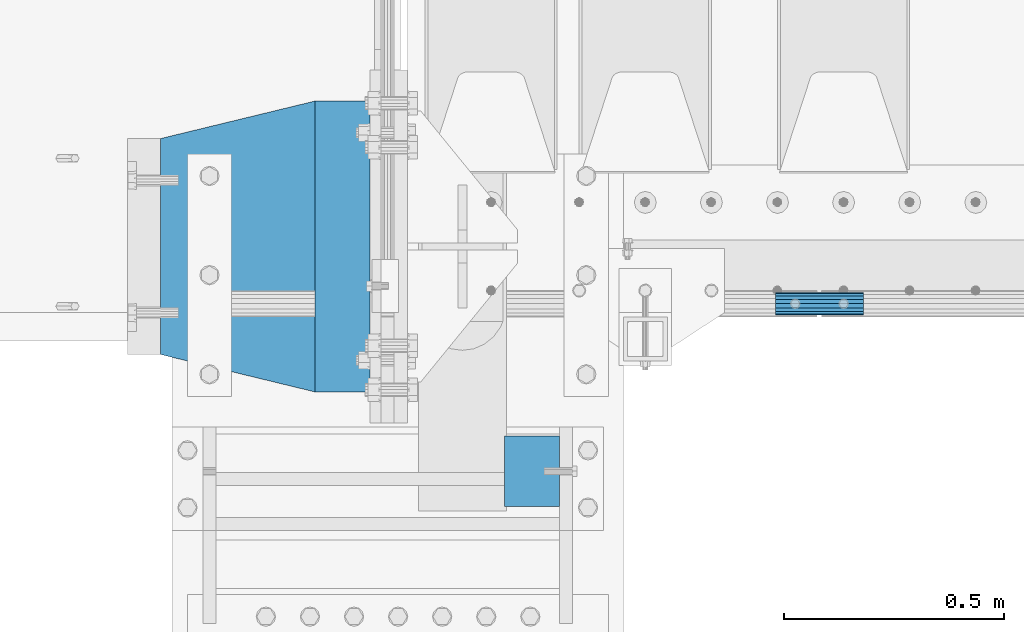
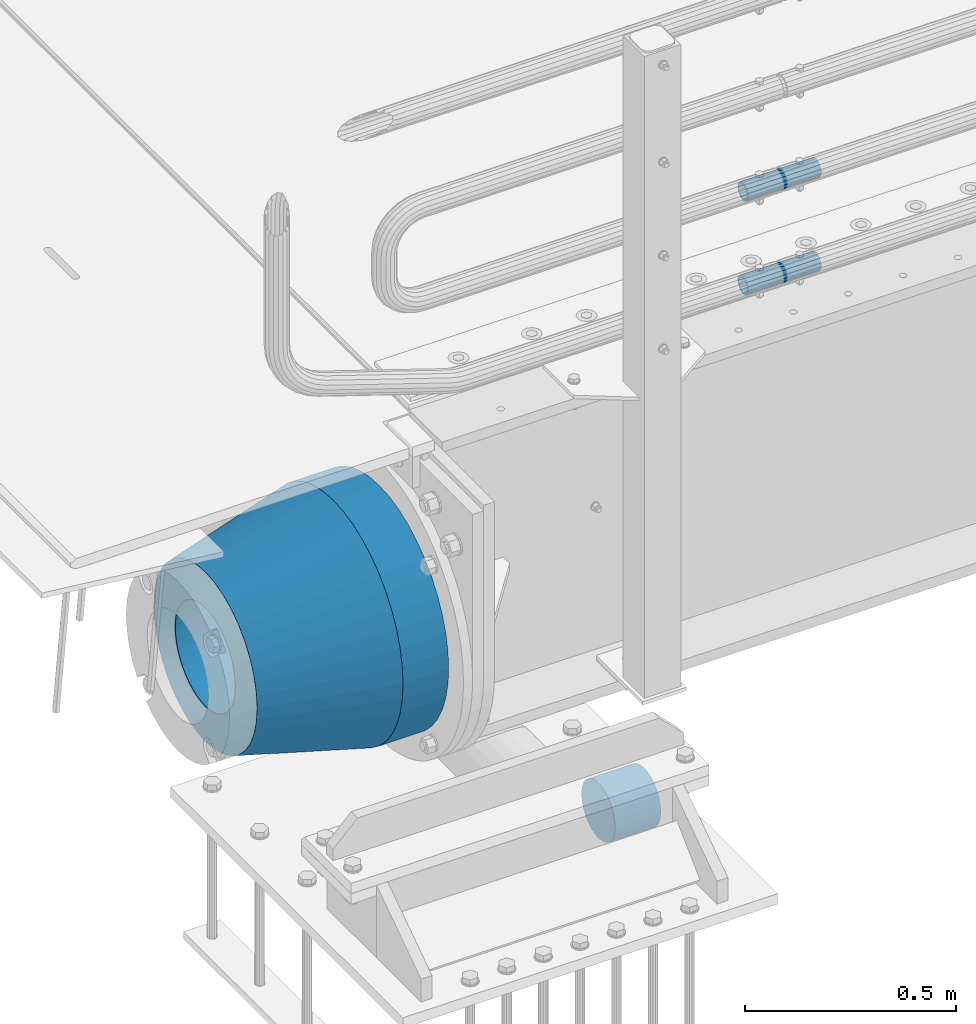
# One storey, part 137 of 257: 5 beams.
"""IFC2X3 building model written with IfcOpenShell, lengths in millimetres."""

from ifc_helpers import new_model, si_unit, frame, origin_with_axes, place, context, subcontext, project, spatial, faceted_brep, material, type_object, element, save


model = new_model("IFC2X3")

# Units and contexts
model_context = context("Model", 3, precision=1e-05, world=origin_with_axes())
body_context = subcontext(model_context, "Body", "Model", "MODEL_VIEW")
ifc_project = project(units=[si_unit("LENGTHUNIT", "METRE", prefix="MILLI"), si_unit("AREAUNIT", "SQUARE_METRE"), si_unit("VOLUMEUNIT", "CUBIC_METRE"), si_unit("MASSUNIT", "GRAM", prefix="KILO"), si_unit("TIMEUNIT", "SECOND"), si_unit("PLANEANGLEUNIT", "RADIAN"), si_unit("SOLIDANGLEUNIT", "STERADIAN"), si_unit("THERMODYNAMICTEMPERATUREUNIT", "DEGREE_CELSIUS"), si_unit("LUMINOUSINTENSITYUNIT", "LUMEN")], contexts=[model_context])

# Site, building, storey
site_placement = place(None, origin_with_axes())
site = spatial("IfcSite", under=ifc_project, at=site_placement, CompositionType="ELEMENT")
building_placement = place(site_placement, origin_with_axes())
building = spatial("IfcBuilding", under=site, at=building_placement, Name="Standard", CompositionType="ELEMENT")
storey_placement = place(building_placement, origin_with_axes())
storey = spatial("IfcBuildingStorey", under=building, at=storey_placement, Name="Undefined", CompositionType="ELEMENT", Elevation=0.0)

# Beams
ifc_material_1 = material()
beam_type_1 = type_object("IfcBeamType", PredefinedType="NOTDEFINED")
beam_1_placement = place(storey_placement, frame((42680.0000000009, -510.0, -923.000000000004), z_axis=(0.0, 0.0, -1.0), x_axis=(1.0, 0.0, 0.0)))
element("IfcBeam", 1, at=beam_1_placement, inside=storey, type_object=beam_type_1, material=ifc_material_1, context=body_context, shape_type="Brep", body=[
    faceted_brep([(0.0, -80.0, 0.0), (0.0, -77.2740661031254, -20.7055236082017), (125.0, -77.2740661031254, -20.7055236082017), (125.0, -80.0, 0.0), (0.0, -69.2820323027551, -40.0), (125.0, -69.2820323027551, -40.0), (0.0, -56.5685424949238, -56.5685424949238), (125.0, -56.5685424949238, -56.5685424949238), (0.0, -39.9999999999999, -69.2820323027552), (125.0, -39.9999999999999, -69.2820323027552), (0.0, -20.7055236082016, -77.2740661031255), (125.0, -20.7055236082016, -77.2740661031255), (0.0, 0.0, -80.0), (125.0, 0.0, -80.0), (0.0, 20.7055236082017, -77.2740661031255), (125.0, 20.7055236082017, -77.2740661031255), (0.0, 40.0, -69.2820323027551), (125.0, 40.0, -69.2820323027551), (0.0, 56.5685424949238, -56.5685424949238), (125.0, 56.5685424949238, -56.5685424949238), (0.0, 69.2820323027552, -40.0), (125.0, 69.2820323027552, -40.0), (0.0, 77.2740661031255, -20.7055236082016), (125.0, 77.2740661031255, -20.7055236082016), (0.0, 80.0, 0.0), (125.0, 80.0, 0.0), (0.0, 77.2740661031255, 20.7055236082017), (125.0, 77.2740661031255, 20.7055236082017), (0.0, 69.2820323027551, 40.0), (125.0, 69.2820323027551, 40.0), (0.0, 56.5685424949238, 56.5685424949238), (125.0, 56.5685424949238, 56.5685424949238), (0.0, 40.0, 69.2820323027551), (125.0, 40.0, 69.2820323027551), (0.0, 20.7055236082017, 77.2740661031255), (125.0, 20.7055236082017, 77.2740661031255), (0.0, 0.0, 80.0), (125.0, 0.0, 80.0), (0.0, -20.7055236082017, 77.2740661031255), (125.0, -20.7055236082017, 77.2740661031255), (0.0, -40.0, 69.2820323027551), (125.0, -40.0, 69.2820323027551), (0.0, -56.5685424949238, 56.5685424949238), (125.0, -56.5685424949238, 56.5685424949238), (0.0, -69.2820323027551, 40.0), (125.0, -69.2820323027551, 40.0), (0.0, -77.2740661031254, 20.7055236082017), (125.0, -77.2740661031254, 20.7055236082017)], [[[0, 1, 2, 3]], [[1, 4, 5, 2]], [[4, 6, 7, 5]], [[6, 8, 9, 7]], [[8, 10, 11, 9]], [[10, 12, 13, 11]], [[12, 14, 15, 13]], [[14, 16, 17, 15]], [[16, 18, 19, 17]], [[18, 20, 21, 19]], [[20, 22, 23, 21]], [[22, 24, 25, 23]], [[24, 26, 27, 25]], [[26, 28, 29, 27]], [[28, 30, 31, 29]], [[30, 32, 33, 31]], [[32, 34, 35, 33]], [[34, 36, 37, 35]], [[36, 38, 39, 37]], [[38, 40, 41, 39]], [[40, 42, 43, 41]], [[42, 44, 45, 43]], [[44, 46, 47, 45]], [[46, 0, 3, 47]], [[5, 7, 9, 11, 13, 15, 17, 19, 21, 23, 25, 27, 29, 31, 33, 35, 37, 39, 41, 43, 45, 47, 3, 2]], [[46, 44, 42, 40, 38, 36, 34, 32, 30, 28, 26, 24, 22, 20, 18, 16, 14, 12, 10, 8, 6, 4, 1, 0]]]),
])
ifc_material_2 = material()
beam_type_2 = type_object("IfcBeamType", PredefinedType="NOTDEFINED")
beam_2_placement = place(storey_placement, frame((43294.9975029999, -129.849999999603, 149.849999999725), z_axis=(0.0, 0.0, 1.0), x_axis=(1.0, 0.0, 0.0)))
element("IfcBeam", 2, at=beam_2_placement, inside=storey, type_object=beam_type_2, material=ifc_material_2, context=body_context, shape_type="Brep", body=[
    faceted_brep([(0.0, -21.8999999999996, 0.0), (0.0, -20.232961761998, 8.38076716879547), (200.0, -20.232961761998, 8.38076716879547), (200.0, -21.8999999999996, 0.0), (0.0, -15.4856385079856, 15.4856385079854), (200.0, -15.4856385079856, 15.4856385079854), (0.0, -8.3807671687955, 20.2329617619972), (200.0, -8.3807671687955, 20.2329617619972), (0.0, 0.0, 21.9), (200.0, 0.0, 21.9), (0.0, 8.3807671687955, 20.2329617619972), (200.0, 8.3807671687955, 20.2329617619972), (0.0, 15.4856385079856, 15.4856385079854), (200.0, 15.4856385079856, 15.4856385079854), (0.0, 20.232961761998, 8.38076716879547), (200.0, 20.232961761998, 8.38076716879547), (0.0, 21.8999999999996, 0.0), (200.0, 21.8999999999996, 0.0), (0.0, 20.232961761998, -8.38076716879547), (200.0, 20.232961761998, -8.38076716879547), (0.0, 15.4856385079856, -15.4856385079854), (200.0, 15.4856385079856, -15.4856385079854), (0.0, 8.3807671687955, -20.2329617619972), (200.0, 8.3807671687955, -20.2329617619972), (0.0, 0.0, -21.9), (200.0, 0.0, -21.9), (0.0, -8.3807671687955, -20.2329617619972), (200.0, -8.3807671687955, -20.2329617619972), (0.0, -15.4856385079856, -15.4856385079854), (200.0, -15.4856385079856, -15.4856385079854), (0.0, -20.232961761998, -8.38076716879547), (200.0, -20.232961761998, -8.38076716879547), (0.0, -25.5, 0.0), (0.0, -23.5589280790373, -9.7584275253098), (200.0, -23.5589280790373, -9.7584275253098), (200.0, -25.5, 0.0), (0.0, -18.0312229202573, -18.031222920257), (200.0, -18.0312229202573, -18.031222920257), (0.0, -9.75842752531025, -23.5589280790378), (200.0, -9.75842752531025, -23.5589280790378), (0.0, 0.0, -25.5), (200.0, 0.0, -25.5), (0.0, 9.75842752531025, -23.5589280790378), (200.0, 9.75842752531025, -23.5589280790378), (0.0, 18.0312229202573, -18.031222920257), (200.0, 18.0312229202573, -18.031222920257), (0.0, 23.5589280790373, -9.7584275253098), (200.0, 23.5589280790373, -9.7584275253098), (0.0, 25.5, 0.0), (200.0, 25.5, 0.0), (0.0, 23.5589280790373, 9.7584275253098), (200.0, 23.5589280790373, 9.7584275253098), (0.0, 18.0312229202573, 18.031222920257), (200.0, 18.0312229202573, 18.031222920257), (0.0, 9.75842752531025, 23.5589280790378), (200.0, 9.75842752531025, 23.5589280790378), (0.0, 0.0, 25.5), (200.0, 0.0, 25.5), (0.0, -9.75842752531025, 23.5589280790378), (200.0, -9.75842752531025, 23.5589280790378), (0.0, -18.0312229202573, 18.031222920257), (200.0, -18.0312229202573, 18.031222920257), (0.0, -23.5589280790373, 9.7584275253098), (200.0, -23.5589280790373, 9.7584275253098)], [[[0, 1, 2, 3]], [[1, 4, 5, 2]], [[4, 6, 7, 5]], [[6, 8, 9, 7]], [[8, 10, 11, 9]], [[10, 12, 13, 11]], [[12, 14, 15, 13]], [[14, 16, 17, 15]], [[16, 18, 19, 17]], [[18, 20, 21, 19]], [[20, 22, 23, 21]], [[22, 24, 25, 23]], [[24, 26, 27, 25]], [[26, 28, 29, 27]], [[28, 30, 31, 29]], [[30, 0, 3, 31]], [[32, 33, 34, 35]], [[33, 36, 37, 34]], [[36, 38, 39, 37]], [[38, 40, 41, 39]], [[40, 42, 43, 41]], [[42, 44, 45, 43]], [[44, 46, 47, 45]], [[46, 48, 49, 47]], [[48, 50, 51, 49]], [[50, 52, 53, 51]], [[52, 54, 55, 53]], [[54, 56, 57, 55]], [[56, 58, 59, 57]], [[58, 60, 61, 59]], [[60, 62, 63, 61]], [[62, 32, 35, 63]], [[37, 39, 41, 43, 45, 47, 49, 51, 53, 55, 57, 59, 61, 63, 35, 34], [5, 7, 9, 11, 13, 15, 17, 19, 21, 23, 25, 27, 29, 31, 3, 2]], [[62, 60, 58, 56, 54, 52, 50, 48, 46, 44, 42, 40, 38, 36, 33, 32], [30, 28, 26, 24, 22, 20, 18, 16, 14, 12, 10, 8, 6, 4, 1, 0]]]),
])
beam_3_placement = place(storey_placement, frame((43294.9975029999, -129.849999999603, 420.149999999724), z_axis=(0.0, 0.0, 1.0), x_axis=(1.0, 0.0, 0.0)))
element("IfcBeam", 3, at=beam_3_placement, inside=storey, type_object=beam_type_2, material=ifc_material_2, context=body_context, shape_type="Brep", body=[
    faceted_brep([(0.0, -21.8999999999996, 0.0), (0.0, -20.232961761998, 8.38076716879547), (200.0, -20.232961761998, 8.38076716879547), (200.0, -21.8999999999996, 0.0), (0.0, -15.4856385079856, 15.4856385079854), (200.0, -15.4856385079856, 15.4856385079854), (0.0, -8.3807671687955, 20.2329617619972), (200.0, -8.3807671687955, 20.2329617619972), (0.0, 0.0, 21.9), (200.0, 0.0, 21.9), (0.0, 8.3807671687955, 20.2329617619972), (200.0, 8.3807671687955, 20.2329617619972), (0.0, 15.4856385079856, 15.4856385079854), (200.0, 15.4856385079856, 15.4856385079854), (0.0, 20.232961761998, 8.38076716879547), (200.0, 20.232961761998, 8.38076716879547), (0.0, 21.8999999999996, 0.0), (200.0, 21.8999999999996, 0.0), (0.0, 20.232961761998, -8.38076716879547), (200.0, 20.232961761998, -8.38076716879547), (0.0, 15.4856385079856, -15.4856385079854), (200.0, 15.4856385079856, -15.4856385079854), (0.0, 8.3807671687955, -20.2329617619972), (200.0, 8.3807671687955, -20.2329617619972), (0.0, 0.0, -21.9), (200.0, 0.0, -21.9), (0.0, -8.3807671687955, -20.2329617619972), (200.0, -8.3807671687955, -20.2329617619972), (0.0, -15.4856385079856, -15.4856385079854), (200.0, -15.4856385079856, -15.4856385079854), (0.0, -20.232961761998, -8.38076716879547), (200.0, -20.232961761998, -8.38076716879547), (0.0, -25.5, 0.0), (0.0, -23.5589280790373, -9.7584275253098), (200.0, -23.5589280790373, -9.7584275253098), (200.0, -25.5, 0.0), (0.0, -18.0312229202573, -18.031222920257), (200.0, -18.0312229202573, -18.031222920257), (0.0, -9.75842752531025, -23.5589280790378), (200.0, -9.75842752531025, -23.5589280790378), (0.0, 0.0, -25.5), (200.0, 0.0, -25.5), (0.0, 9.75842752531025, -23.5589280790378), (200.0, 9.75842752531025, -23.5589280790378), (0.0, 18.0312229202573, -18.031222920257), (200.0, 18.0312229202573, -18.031222920257), (0.0, 23.5589280790373, -9.7584275253098), (200.0, 23.5589280790373, -9.7584275253098), (0.0, 25.5, 0.0), (200.0, 25.5, 0.0), (0.0, 23.5589280790373, 9.7584275253098), (200.0, 23.5589280790373, 9.7584275253098), (0.0, 18.0312229202573, 18.031222920257), (200.0, 18.0312229202573, 18.031222920257), (0.0, 9.75842752531025, 23.5589280790378), (200.0, 9.75842752531025, 23.5589280790378), (0.0, 0.0, 25.5), (200.0, 0.0, 25.5), (0.0, -9.75842752531025, 23.5589280790378), (200.0, -9.75842752531025, 23.5589280790378), (0.0, -18.0312229202573, 18.031222920257), (200.0, -18.0312229202573, 18.031222920257), (0.0, -23.5589280790373, 9.7584275253098), (200.0, -23.5589280790373, 9.7584275253098)], [[[0, 1, 2, 3]], [[1, 4, 5, 2]], [[4, 6, 7, 5]], [[6, 8, 9, 7]], [[8, 10, 11, 9]], [[10, 12, 13, 11]], [[12, 14, 15, 13]], [[14, 16, 17, 15]], [[16, 18, 19, 17]], [[18, 20, 21, 19]], [[20, 22, 23, 21]], [[22, 24, 25, 23]], [[24, 26, 27, 25]], [[26, 28, 29, 27]], [[28, 30, 31, 29]], [[30, 0, 3, 31]], [[32, 33, 34, 35]], [[33, 36, 37, 34]], [[36, 38, 39, 37]], [[38, 40, 41, 39]], [[40, 42, 43, 41]], [[42, 44, 45, 43]], [[44, 46, 47, 45]], [[46, 48, 49, 47]], [[48, 50, 51, 49]], [[50, 52, 53, 51]], [[52, 54, 55, 53]], [[54, 56, 57, 55]], [[56, 58, 59, 57]], [[58, 60, 61, 59]], [[60, 62, 63, 61]], [[62, 32, 35, 63]], [[37, 39, 41, 43, 45, 47, 49, 51, 53, 55, 57, 59, 61, 63, 35, 34], [5, 7, 9, 11, 13, 15, 17, 19, 21, 23, 25, 27, 29, 31, 3, 2]], [[62, 60, 58, 56, 54, 52, 50, 48, 46, 44, 42, 40, 38, 36, 33, 32], [30, 28, 26, 24, 22, 20, 18, 16, 14, 12, 10, 8, 6, 4, 1, 0]]]),
])
ifc_material_3 = material(Name="STEEL/S355N")
beam_type_3 = type_object("IfcBeamType", PredefinedType="NOTDEFINED")
beam_4_placement = place(storey_placement, frame((42375.0, 0.0, -515.0), z_axis=(0.0, 0.0, 1.0), x_axis=(-1.0, 0.0, 0.0)))
element("IfcBeam", 4, at=beam_4_placement, inside=storey, type_object=beam_type_3, material=ifc_material_3, context=body_context, shape_type="Brep", body=[
    faceted_brep([(0.0, -215.0, 0.0), (0.0, -212.811610004401, 30.5976902287563), (125.0, -212.811610004401, 30.5976902287563), (125.0, -215.0, 0.0), (0.0, -206.290989327117, 60.5724997209074), (125.0, -206.290989327117, 60.5724997209074), (0.0, -195.570879001221, 89.3142277954056), (125.0, -195.570879001221, 89.3142277954056), (0.0, -180.869509558704, 116.237775752953), (125.0, -180.869509558704, 116.237775752953), (0.0, -162.486158486166, 140.795057798236), (125.0, -162.486158486166, 140.795057798236), (0.0, -140.795057798236, 162.486158486165), (125.0, -140.795057798236, 162.486158486165), (0.0, -116.237775752953, 180.869509558704), (125.0, -116.237775752953, 180.869509558704), (0.0, -89.3142277954055, 195.570879001222), (125.0, -89.3142277954055, 195.570879001222), (0.0, -60.5724997209073, 206.290989327117), (125.0, -60.5724997209073, 206.290989327117), (0.0, -30.5976902287562, 212.811610004401), (125.0, -30.5976902287562, 212.811610004401), (0.0, 3.94948592725021e-14, 215.0), (125.0, 3.94948592725021e-14, 215.0), (0.0, 30.5976902287563, 212.811610004401), (125.0, 30.5976902287563, 212.811610004401), (0.0, 60.5724997209074, 206.290989327117), (125.0, 60.5724997209074, 206.290989327117), (0.0, 89.3142277954056, 195.570879001221), (125.0, 89.3142277954056, 195.570879001221), (0.0, 116.237775752953, 180.869509558704), (125.0, 116.237775752953, 180.869509558704), (0.0, 140.795057798236, 162.486158486165), (125.0, 140.795057798236, 162.486158486165), (0.0, 162.486158486166, 140.795057798236), (125.0, 162.486158486166, 140.795057798236), (0.0, 180.869509558704, 116.237775752953), (125.0, 180.869509558704, 116.237775752953), (0.0, 195.570879001221, 89.3142277954056), (125.0, 195.570879001221, 89.3142277954056), (0.0, 206.290989327117, 60.5724997209073), (125.0, 206.290989327117, 60.5724997209073), (0.0, 212.811610004401, 30.5976902287563), (125.0, 212.811610004401, 30.5976902287563), (0.0, 215.0, 0.0), (125.0, 215.0, 0.0), (0.0, 212.811610004401, -30.5976902287563), (125.0, 212.811610004401, -30.5976902287563), (0.0, 206.290989327117, -60.5724997209073), (125.0, 206.290989327117, -60.5724997209073), (0.0, 195.570879001221, -89.3142277954056), (125.0, 195.570879001221, -89.3142277954056), (0.0, 180.869509558704, -116.237775752954), (125.0, 180.869509558704, -116.237775752954), (0.0, 162.486158486165, -140.795057798236), (125.0, 162.486158486165, -140.795057798236), (0.0, 140.795057798236, -162.486158486166), (125.0, 140.795057798236, -162.486158486166), (0.0, 116.237775752953, -180.869509558704), (125.0, 116.237775752953, -180.869509558704), (0.0, 89.3142277954056, -195.570879001221), (125.0, 89.3142277954056, -195.570879001221), (0.0, 60.5724997209074, -206.290989327117), (125.0, 60.5724997209074, -206.290989327117), (0.0, 30.5976902287563, -212.811610004401), (125.0, 30.5976902287563, -212.811610004401), (0.0, -1.3164953090834e-14, -215.0), (125.0, -1.3164953090834e-14, -215.0), (0.0, -30.5976902287563, -212.811610004401), (125.0, -30.5976902287563, -212.811610004401), (0.0, -60.5724997209074, -206.290989327117), (125.0, -60.5724997209074, -206.290989327117), (0.0, -89.3142277954056, -195.570879001221), (125.0, -89.3142277954056, -195.570879001221), (0.0, -116.237775752954, -180.869509558704), (125.0, -116.237775752954, -180.869509558704), (0.0, -140.795057798236, -162.486158486166), (125.0, -140.795057798236, -162.486158486166), (0.0, -162.486158486166, -140.795057798236), (125.0, -162.486158486166, -140.795057798236), (0.0, -180.869509558704, -116.237775752953), (125.0, -180.869509558704, -116.237775752953), (0.0, -195.570879001221, -89.3142277954056), (125.0, -195.570879001221, -89.3142277954056), (0.0, -206.290989327117, -60.5724997209073), (125.0, -206.290989327117, -60.5724997209073), (0.0, -212.811610004401, -30.5976902287563), (125.0, -212.811610004401, -30.5976902287563), (0.0, -330.0, 0.0), (0.0, -326.641075820708, -46.9638966301842), (125.0, -326.641075820708, -46.9638966301842), (125.0, -330.0, 0.0), (0.0, -316.632681292784, -92.9717437576718), (125.0, -316.632681292784, -92.9717437576718), (0.0, -300.178558466991, -137.086954290623), (125.0, -300.178558466991, -137.086954290623), (0.0, -277.61366583429, -178.411469760347), (125.0, -277.61366583429, -178.411469760347), (0.0, -249.397359536905, -216.104042201944), (125.0, -249.397359536905, -216.104042201944), (0.0, -216.104042201944, -249.397359536905), (125.0, -216.104042201944, -249.397359536905), (0.0, -178.411469760347, -277.61366583429), (125.0, -178.411469760347, -277.61366583429), (0.0, -137.086954290622, -300.178558466991), (125.0, -137.086954290622, -300.178558466991), (0.0, -92.9717437576717, -316.632681292784), (125.0, -92.9717437576717, -316.632681292784), (0.0, -46.963896630184, -326.641075820708), (125.0, -46.963896630184, -326.641075820708), (0.0, 6.0620016557794e-14, -330.0), (125.0, 6.0620016557794e-14, -330.0), (0.0, 46.9638966301841, -326.641075820708), (125.0, 46.9638966301841, -326.641075820708), (0.0, 92.9717437576718, -316.632681292784), (125.0, 92.9717437576718, -316.632681292784), (0.0, 137.086954290623, -300.178558466991), (125.0, 137.086954290623, -300.178558466991), (0.0, 178.411469760347, -277.61366583429), (125.0, 178.411469760347, -277.61366583429), (0.0, 216.104042201944, -249.397359536905), (125.0, 216.104042201944, -249.397359536905), (0.0, 249.397359536905, -216.104042201944), (125.0, 249.397359536905, -216.104042201944), (0.0, 277.61366583429, -178.411469760347), (125.0, 277.61366583429, -178.411469760347), (0.0, 300.178558466991, -137.086954290623), (125.0, 300.178558466991, -137.086954290623), (0.0, 316.632681292784, -92.9717437576717), (125.0, 316.632681292784, -92.9717437576717), (0.0, 326.641075820708, -46.9638966301841), (125.0, 326.641075820708, -46.9638966301841), (0.0, 330.0, 0.0), (125.0, 330.0, 0.0), (0.0, 326.641075820708, 46.9638966301841), (125.0, 326.641075820708, 46.9638966301841), (0.0, 316.632681292784, 92.9717437576718), (125.0, 316.632681292784, 92.9717437576718), (0.0, 300.178558466991, 137.086954290622), (125.0, 300.178558466991, 137.086954290622), (0.0, 277.61366583429, 178.411469760347), (125.0, 277.61366583429, 178.411469760347), (0.0, 249.397359536905, 216.104042201944), (125.0, 249.397359536905, 216.104042201944), (0.0, 216.104042201944, 249.397359536905), (125.0, 216.104042201944, 249.397359536905), (0.0, 178.411469760347, 277.61366583429), (125.0, 178.411469760347, 277.61366583429), (0.0, 137.086954290622, 300.178558466991), (125.0, 137.086954290622, 300.178558466991), (0.0, 92.9717437576718, 316.632681292784), (125.0, 92.9717437576718, 316.632681292784), (0.0, 46.9638966301841, 326.641075820708), (125.0, 46.9638966301841, 326.641075820708), (0.0, -2.02066721859313e-14, 330.0), (125.0, -2.02066721859313e-14, 330.0), (0.0, -46.9638966301841, 326.641075820708), (125.0, -46.9638966301841, 326.641075820708), (0.0, -92.9717437576718, 316.632681292784), (125.0, -92.9717437576718, 316.632681292784), (0.0, -137.086954290623, 300.178558466991), (125.0, -137.086954290623, 300.178558466991), (0.0, -178.411469760347, 277.61366583429), (125.0, -178.411469760347, 277.61366583429), (0.0, -216.104042201944, 249.397359536905), (125.0, -216.104042201944, 249.397359536905), (0.0, -249.397359536905, 216.104042201944), (125.0, -249.397359536905, 216.104042201944), (0.0, -277.61366583429, 178.411469760347), (125.0, -277.61366583429, 178.411469760347), (0.0, -300.178558466991, 137.086954290623), (125.0, -300.178558466991, 137.086954290623), (0.0, -316.632681292784, 92.9717437576718), (125.0, -316.632681292784, 92.9717437576718), (0.0, -326.641075820708, 46.9638966301841), (125.0, -326.641075820708, 46.9638966301841)], [[[0, 1, 2, 3]], [[1, 4, 5, 2]], [[4, 6, 7, 5]], [[6, 8, 9, 7]], [[8, 10, 11, 9]], [[10, 12, 13, 11]], [[12, 14, 15, 13]], [[14, 16, 17, 15]], [[16, 18, 19, 17]], [[18, 20, 21, 19]], [[20, 22, 23, 21]], [[22, 24, 25, 23]], [[24, 26, 27, 25]], [[26, 28, 29, 27]], [[28, 30, 31, 29]], [[30, 32, 33, 31]], [[32, 34, 35, 33]], [[34, 36, 37, 35]], [[36, 38, 39, 37]], [[38, 40, 41, 39]], [[40, 42, 43, 41]], [[42, 44, 45, 43]], [[44, 46, 47, 45]], [[46, 48, 49, 47]], [[48, 50, 51, 49]], [[50, 52, 53, 51]], [[52, 54, 55, 53]], [[54, 56, 57, 55]], [[56, 58, 59, 57]], [[58, 60, 61, 59]], [[60, 62, 63, 61]], [[62, 64, 65, 63]], [[64, 66, 67, 65]], [[66, 68, 69, 67]], [[68, 70, 71, 69]], [[70, 72, 73, 71]], [[72, 74, 75, 73]], [[74, 76, 77, 75]], [[76, 78, 79, 77]], [[78, 80, 81, 79]], [[80, 82, 83, 81]], [[82, 84, 85, 83]], [[84, 86, 87, 85]], [[86, 0, 3, 87]], [[88, 89, 90, 91]], [[89, 92, 93, 90]], [[92, 94, 95, 93]], [[94, 96, 97, 95]], [[96, 98, 99, 97]], [[98, 100, 101, 99]], [[100, 102, 103, 101]], [[102, 104, 105, 103]], [[104, 106, 107, 105]], [[106, 108, 109, 107]], [[108, 110, 111, 109]], [[110, 112, 113, 111]], [[112, 114, 115, 113]], [[114, 116, 117, 115]], [[116, 118, 119, 117]], [[118, 120, 121, 119]], [[120, 122, 123, 121]], [[122, 124, 125, 123]], [[124, 126, 127, 125]], [[126, 128, 129, 127]], [[128, 130, 131, 129]], [[130, 132, 133, 131]], [[132, 134, 135, 133]], [[134, 136, 137, 135]], [[136, 138, 139, 137]], [[138, 140, 141, 139]], [[140, 142, 143, 141]], [[142, 144, 145, 143]], [[144, 146, 147, 145]], [[146, 148, 149, 147]], [[148, 150, 151, 149]], [[150, 152, 153, 151]], [[152, 154, 155, 153]], [[154, 156, 157, 155]], [[156, 158, 159, 157]], [[158, 160, 161, 159]], [[160, 162, 163, 161]], [[162, 164, 165, 163]], [[164, 166, 167, 165]], [[166, 168, 169, 167]], [[168, 170, 171, 169]], [[170, 172, 173, 171]], [[172, 174, 175, 173]], [[174, 88, 91, 175]], [[93, 95, 97, 99, 101, 103, 105, 107, 109, 111, 113, 115, 117, 119, 121, 123, 125, 127, 129, 131, 133, 135, 137, 139, 141, 143, 145, 147, 149, 151, 153, 155, 157, 159, 161, 163, 165, 167, 169, 171, 173, 175, 91, 90], [5, 7, 9, 11, 13, 15, 17, 19, 21, 23, 25, 27, 29, 31, 33, 35, 37, 39, 41, 43, 45, 47, 49, 51, 53, 55, 57, 59, 61, 63, 65, 67, 69, 71, 73, 75, 77, 79, 81, 83, 85, 87, 3, 2]], [[174, 172, 170, 168, 166, 164, 162, 160, 158, 156, 154, 152, 150, 148, 146, 144, 142, 140, 138, 136, 134, 132, 130, 128, 126, 124, 122, 120, 118, 116, 114, 112, 110, 108, 106, 104, 102, 100, 98, 96, 94, 92, 89, 88], [86, 84, 82, 80, 78, 76, 74, 72, 70, 68, 66, 64, 62, 60, 58, 56, 54, 52, 50, 48, 46, 44, 42, 40, 38, 36, 34, 32, 30, 28, 26, 24, 22, 20, 18, 16, 14, 12, 10, 8, 6, 4, 1, 0]]]),
])
ifc_material_4 = material(Name="SCN-500-E2")
beam_type_4 = type_object("IfcBeamType", PredefinedType="NOTDEFINED")
beam_5_placement = place(storey_placement, frame((42250.0, 0.0, -515.0), z_axis=(0.0, 0.0, 1.0), x_axis=(-1.0, 0.0, 0.0)))
element("IfcBeam", 5, at=beam_5_placement, inside=storey, type_object=beam_type_4, material=ifc_material_4, context=body_context, shape_type="Brep", body=[
    faceted_brep([(0.0, -330.0, 0.0), (0.0, -326.641075820708, -46.9638966301842), (350.0, -242.506253260829, -34.8671353769549), (350.0, -245.0, 0.0), (0.0, -316.632681292784, -92.9717437576718), (350.0, -235.075778535552, -69.0244764261503), (0.0, -300.178558466991, -137.086954290623), (350.0, -222.859838861857, -101.776678185462), (0.0, -277.61366583429, -178.411469760347), (350.0, -206.107115543639, -132.457000276621), (0.0, -249.397359536905, -216.104042201944), (350.0, -185.158645716793, -160.440879816595), (0.0, -216.104042201944, -249.397359536905), (350.0, -160.440879816595, -185.158645716793), (0.0, -178.411469760347, -277.61366583429), (350.0, -132.457000276621, -206.107115543639), (0.0, -137.086954290622, -300.178558466991), (350.0, -101.776678185462, -222.859838861857), (0.0, -92.9717437576717, -316.632681292784), (350.0, -69.0244764261502, -235.075778535552), (0.0, -46.963896630184, -326.641075820708), (350.0, -34.8671353769548, -242.506253260829), (0.0, 6.0620016557794e-14, -330.0), (350.0, 4.50057698686652e-14, -245.0), (0.0, 46.9638966301841, -326.641075820708), (350.0, 34.8671353769549, -242.506253260829), (0.0, 92.9717437576718, -316.632681292784), (350.0, 69.0244764261503, -235.075778535552), (0.0, 137.086954290623, -300.178558466991), (350.0, 101.776678185462, -222.859838861857), (0.0, 178.411469760347, -277.61366583429), (350.0, 132.457000276621, -206.107115543639), (0.0, 216.104042201944, -249.397359536905), (350.0, 160.440879816595, -185.158645716793), (0.0, 249.397359536905, -216.104042201944), (350.0, 185.158645716793, -160.440879816595), (0.0, 277.61366583429, -178.411469760347), (350.0, 206.107115543639, -132.457000276621), (0.0, 300.178558466991, -137.086954290623), (350.0, 222.859838861857, -101.776678185462), (0.0, 316.632681292784, -92.9717437576717), (350.0, 235.075778535552, -69.0244764261502), (0.0, 326.641075820708, -46.9638966301841), (350.0, 242.506253260829, -34.8671353769548), (0.0, 330.0, 0.0), (350.0, 245.0, 0.0), (0.0, 326.641075820708, 46.9638966301841), (350.0, 242.506253260829, 34.8671353769549), (0.0, 316.632681292784, 92.9717437576718), (350.0, 235.075778535552, 69.0244764261503), (0.0, 300.178558466991, 137.086954290622), (350.0, 222.859838861857, 101.776678185462), (0.0, 277.61366583429, 178.411469760347), (350.0, 206.107115543639, 132.457000276621), (0.0, 249.397359536905, 216.104042201944), (350.0, 185.158645716793, 160.440879816595), (0.0, 216.104042201944, 249.397359536905), (350.0, 160.440879816595, 185.158645716793), (0.0, 178.411469760347, 277.61366583429), (350.0, 132.457000276621, 206.107115543639), (0.0, 137.086954290622, 300.178558466991), (350.0, 101.776678185462, 222.859838861857), (0.0, 92.9717437576718, 316.632681292784), (350.0, 69.0244764261503, 235.075778535552), (0.0, 46.9638966301841, 326.641075820708), (350.0, 34.8671353769548, 242.506253260829), (0.0, -2.02066721859313e-14, 330.0), (350.0, -1.50019232895551e-14, 245.0), (0.0, -46.9638966301841, 326.641075820708), (350.0, -34.8671353769549, 242.506253260829), (0.0, -92.9717437576718, 316.632681292784), (350.0, -69.0244764261503, 235.075778535552), (0.0, -137.086954290623, 300.178558466991), (350.0, -101.776678185462, 222.859838861857), (0.0, -178.411469760347, 277.61366583429), (350.0, -132.457000276621, 206.107115543639), (0.0, -216.104042201944, 249.397359536905), (350.0, -160.440879816595, 185.158645716793), (0.0, -249.397359536905, 216.104042201944), (350.0, -185.158645716793, 160.440879816595), (0.0, -277.61366583429, 178.411469760347), (350.0, -206.107115543639, 132.457000276621), (0.0, -300.178558466991, 137.086954290623), (350.0, -222.859838861857, 101.776678185462), (0.0, -316.632681292784, 92.9717437576718), (350.0, -235.075778535552, 69.0244764261503), (0.0, -326.641075820708, 46.9638966301841), (350.0, -242.506253260829, 34.8671353769549), (0.0, -227.093265923131, 0.0), (0.0, -224.781783917484, 32.3187414128026), (350.0, -140.646961357605, 20.2219801595734), (350.0, -142.093265923131, 0.0), (0.0, -217.894393008413, 63.9795664499945), (350.0, -136.337490251181, 40.032299118473), (0.0, -206.571300613232, 94.3379520160985), (350.0, -129.252581008098, 59.0276759109381), (0.0, -191.043012240005, 122.775888927343), (350.0, -119.536461949355, 76.8214194436173), (0.0, -171.625639060125, 148.714462796454), (350.0, -107.386925240013, 93.0513004111044), (0.0, -148.714462796454, 171.625639060125), (350.0, -93.0513004111044, 107.386925240013), (0.0, -122.775888927343, 191.043012240005), (350.0, -76.8214194436173, 119.536461949355), (0.0, -94.3379520160984, 206.571300613232), (350.0, -59.0276759109381, 129.252581008098), (0.0, -63.9795664499945, 217.894393008413), (350.0, -40.032299118473, 136.337490251181), (0.0, -32.3187414128025, 224.781783917484), (350.0, -20.2219801595733, 140.646961357605), (0.0, 4.17163561831022e-14, 227.093265923131), (350.0, 2.61021094939735e-14, 142.093265923131), (0.0, 32.3187414128026, 224.781783917484), (350.0, 20.2219801595734, 140.646961357605), (0.0, 63.9795664499945, 217.894393008413), (350.0, 40.032299118473, 136.337490251181), (0.0, 94.3379520160985, 206.571300613232), (350.0, 59.0276759109381, 129.252581008098), (0.0, 122.775888927343, 191.043012240005), (350.0, 76.8214194436174, 119.536461949355), (0.0, 148.714462796454, 171.625639060125), (350.0, 93.0513004111044, 107.386925240013), (0.0, 171.625639060125, 148.714462796454), (350.0, 107.386925240013, 93.0513004111044), (0.0, 191.043012240005, 122.775888927343), (350.0, 119.536461949355, 76.8214194436174), (0.0, 206.571300613232, 94.3379520160985), (350.0, 129.252581008098, 59.0276759109382), (0.0, 217.894393008413, 63.9795664499945), (350.0, 136.337490251181, 40.032299118473), (0.0, 224.781783917484, 32.3187414128025), (350.0, 140.646961357605, 20.2219801595733), (0.0, 227.093265923131, 0.0), (350.0, 142.093265923131, 0.0), (0.0, 224.781783917484, -32.3187414128026), (350.0, 140.646961357605, -20.2219801595734), (0.0, 217.894393008413, -63.9795664499945), (350.0, 136.337490251181, -40.032299118473), (0.0, 206.571300613232, -94.3379520160985), (350.0, 129.252581008098, -59.0276759109381), (0.0, 191.043012240005, -122.775888927343), (350.0, 119.536461949355, -76.8214194436174), (0.0, 171.625639060125, -148.714462796454), (350.0, 107.386925240013, -93.0513004111044), (0.0, 148.714462796454, -171.625639060125), (350.0, 93.0513004111044, -107.386925240013), (0.0, 122.775888927343, -191.043012240005), (350.0, 76.8214194436174, -119.536461949355), (0.0, 94.3379520160985, -206.571300613232), (350.0, 59.0276759109381, -129.252581008098), (0.0, 63.9795664499945, -217.894393008413), (350.0, 40.032299118473, -136.337490251181), (0.0, 32.3187414128026, -224.781783917484), (350.0, 20.2219801595733, -140.646961357605), (0.0, -1.39054520610341e-14, -227.093265923131), (350.0, -8.70070316465783e-15, -142.093265923131), (0.0, -32.3187414128026, -224.781783917484), (350.0, -20.2219801595733, -140.646961357605), (0.0, -63.9795664499946, -217.894393008413), (350.0, -40.032299118473, -136.337490251181), (0.0, -94.3379520160985, -206.571300613232), (350.0, -59.0276759109381, -129.252581008098), (0.0, -122.775888927343, -191.043012240005), (350.0, -76.8214194436174, -119.536461949355), (0.0, -148.714462796454, -171.625639060125), (350.0, -93.0513004111044, -107.386925240013), (0.0, -171.625639060125, -148.714462796454), (350.0, -107.386925240013, -93.0513004111044), (0.0, -191.043012240005, -122.775888927343), (350.0, -119.536461949355, -76.8214194436174), (0.0, -206.571300613232, -94.3379520160985), (350.0, -129.252581008098, -59.0276759109381), (0.0, -217.894393008413, -63.9795664499945), (350.0, -136.337490251181, -40.032299118473), (0.0, -224.781783917484, -32.3187414128026), (350.0, -140.646961357605, -20.2219801595734)], [[[0, 1, 2, 3]], [[1, 4, 5, 2]], [[4, 6, 7, 5]], [[6, 8, 9, 7]], [[8, 10, 11, 9]], [[10, 12, 13, 11]], [[12, 14, 15, 13]], [[14, 16, 17, 15]], [[16, 18, 19, 17]], [[18, 20, 21, 19]], [[20, 22, 23, 21]], [[22, 24, 25, 23]], [[24, 26, 27, 25]], [[26, 28, 29, 27]], [[28, 30, 31, 29]], [[30, 32, 33, 31]], [[32, 34, 35, 33]], [[34, 36, 37, 35]], [[36, 38, 39, 37]], [[38, 40, 41, 39]], [[40, 42, 43, 41]], [[42, 44, 45, 43]], [[44, 46, 47, 45]], [[46, 48, 49, 47]], [[48, 50, 51, 49]], [[50, 52, 53, 51]], [[52, 54, 55, 53]], [[54, 56, 57, 55]], [[56, 58, 59, 57]], [[58, 60, 61, 59]], [[60, 62, 63, 61]], [[62, 64, 65, 63]], [[64, 66, 67, 65]], [[66, 68, 69, 67]], [[68, 70, 71, 69]], [[70, 72, 73, 71]], [[72, 74, 75, 73]], [[74, 76, 77, 75]], [[76, 78, 79, 77]], [[78, 80, 81, 79]], [[80, 82, 83, 81]], [[82, 84, 85, 83]], [[84, 86, 87, 85]], [[86, 0, 3, 87]], [[88, 89, 90, 91]], [[89, 92, 93, 90]], [[92, 94, 95, 93]], [[94, 96, 97, 95]], [[96, 98, 99, 97]], [[98, 100, 101, 99]], [[100, 102, 103, 101]], [[102, 104, 105, 103]], [[104, 106, 107, 105]], [[106, 108, 109, 107]], [[108, 110, 111, 109]], [[110, 112, 113, 111]], [[112, 114, 115, 113]], [[114, 116, 117, 115]], [[116, 118, 119, 117]], [[118, 120, 121, 119]], [[120, 122, 123, 121]], [[122, 124, 125, 123]], [[124, 126, 127, 125]], [[126, 128, 129, 127]], [[128, 130, 131, 129]], [[130, 132, 133, 131]], [[132, 134, 135, 133]], [[134, 136, 137, 135]], [[136, 138, 139, 137]], [[138, 140, 141, 139]], [[140, 142, 143, 141]], [[142, 144, 145, 143]], [[144, 146, 147, 145]], [[146, 148, 149, 147]], [[148, 150, 151, 149]], [[150, 152, 153, 151]], [[152, 154, 155, 153]], [[154, 156, 157, 155]], [[156, 158, 159, 157]], [[158, 160, 161, 159]], [[160, 162, 163, 161]], [[162, 164, 165, 163]], [[164, 166, 167, 165]], [[166, 168, 169, 167]], [[168, 170, 171, 169]], [[170, 172, 173, 171]], [[172, 174, 175, 173]], [[174, 88, 91, 175]], [[5, 7, 9, 11, 13, 15, 17, 19, 21, 23, 25, 27, 29, 31, 33, 35, 37, 39, 41, 43, 45, 47, 49, 51, 53, 55, 57, 59, 61, 63, 65, 67, 69, 71, 73, 75, 77, 79, 81, 83, 85, 87, 3, 2], [93, 95, 97, 99, 101, 103, 105, 107, 109, 111, 113, 115, 117, 119, 121, 123, 125, 127, 129, 131, 133, 135, 137, 139, 141, 143, 145, 147, 149, 151, 153, 155, 157, 159, 161, 163, 165, 167, 169, 171, 173, 175, 91, 90]], [[86, 84, 82, 80, 78, 76, 74, 72, 70, 68, 66, 64, 62, 60, 58, 56, 54, 52, 50, 48, 46, 44, 42, 40, 38, 36, 34, 32, 30, 28, 26, 24, 22, 20, 18, 16, 14, 12, 10, 8, 6, 4, 1, 0], [174, 172, 170, 168, 166, 164, 162, 160, 158, 156, 154, 152, 150, 148, 146, 144, 142, 140, 138, 136, 134, 132, 130, 128, 126, 124, 122, 120, 118, 116, 114, 112, 110, 108, 106, 104, 102, 100, 98, 96, 94, 92, 89, 88]]]),
])

save(model, "model.ifc")
